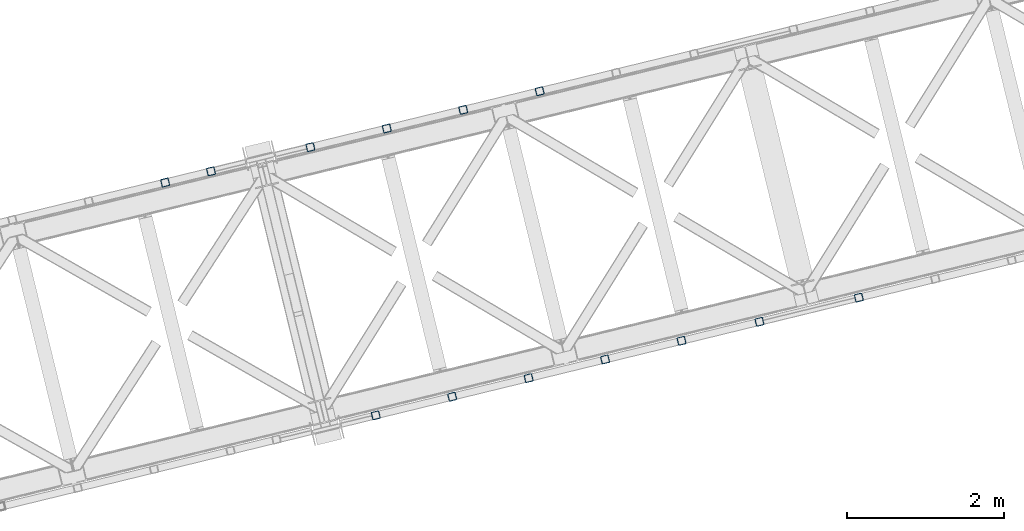
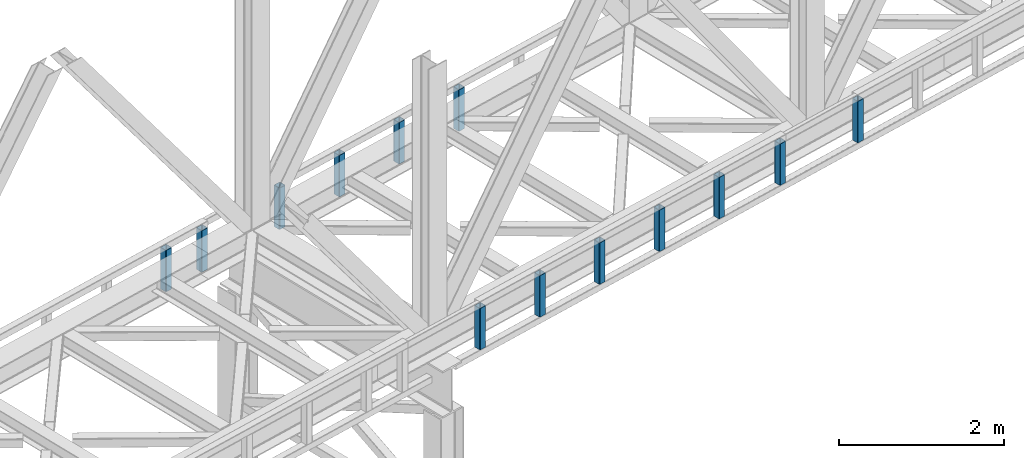
# One storey, part 9 of 93: 13 columns.
"""IFC4 building model written with IfcOpenShell, lengths in millimetres."""

from ifc_helpers import new_model, entity, si_unit, converted_unit, derived_unit, direction, frame, origin, place, context, subcontext, project, spatial, indexed_curve, outline, extrude, type_object, element, save


model = new_model("IFC4")

# Units and contexts
model_context = context("Model", 3, precision=0.01, world=origin(), true_north=direction((6.12303176911189e-17, 1.0)))
plan_context = context("Plan", 3, precision=0.01, world=origin(), true_north=direction((6.12303176911189e-17, 1.0)))
body_context = subcontext(model_context, "Body", "Model", "MODEL_VIEW")
ifc_project = project(units=[si_unit("LENGTHUNIT", "METRE", prefix="MILLI"), si_unit("AREAUNIT", "SQUARE_METRE"), si_unit("VOLUMEUNIT", "CUBIC_METRE"), converted_unit("PLANEANGLEUNIT", "DEGREE", entity("IfcRatioMeasure", 0.0174532925199433), si_unit("PLANEANGLEUNIT", "RADIAN"), dimensions=[0, 0, 0, 0, 0, 0, 0]), si_unit("MASSUNIT", "GRAM", prefix="KILO"), derived_unit("MASSDENSITYUNIT", [(si_unit("MASSUNIT", "GRAM", prefix="KILO"), 1), (si_unit("LENGTHUNIT", "METRE"), -3)]), derived_unit("MOMENTOFINERTIAUNIT", [(si_unit("LENGTHUNIT", "METRE"), 4)]), si_unit("TIMEUNIT", "SECOND"), si_unit("FREQUENCYUNIT", "HERTZ"), si_unit("THERMODYNAMICTEMPERATUREUNIT", "DEGREE_CELSIUS"), derived_unit("THERMALTRANSMITTANCEUNIT", [(si_unit("MASSUNIT", "GRAM", prefix="KILO"), 1), (si_unit("THERMODYNAMICTEMPERATUREUNIT", "KELVIN"), -1), (si_unit("TIMEUNIT", "SECOND"), -3)]), derived_unit("VOLUMETRICFLOWRATEUNIT", [(si_unit("LENGTHUNIT", "METRE"), 3), (si_unit("TIMEUNIT", "SECOND"), -1)]), derived_unit("MASSFLOWRATEUNIT", [(si_unit("MASSUNIT", "GRAM", prefix="KILO"), 1), (si_unit("TIMEUNIT", "SECOND"), -1)]), derived_unit("ROTATIONALFREQUENCYUNIT", [(si_unit("TIMEUNIT", "SECOND"), -1)]), si_unit("ELECTRICCURRENTUNIT", "AMPERE"), si_unit("ELECTRICVOLTAGEUNIT", "VOLT"), si_unit("POWERUNIT", "WATT"), si_unit("FORCEUNIT", "NEWTON", prefix="KILO"), si_unit("ILLUMINANCEUNIT", "LUX"), si_unit("LUMINOUSFLUXUNIT", "LUMEN"), si_unit("LUMINOUSINTENSITYUNIT", "CANDELA"), derived_unit("USERDEFINED", [(si_unit("MASSUNIT", "GRAM", prefix="KILO"), -1), (si_unit("LENGTHUNIT", "METRE"), -2), (si_unit("TIMEUNIT", "SECOND"), 3), (si_unit("LUMINOUSFLUXUNIT", "LUMEN"), 1)]), derived_unit("LINEARVELOCITYUNIT", [(si_unit("LENGTHUNIT", "METRE"), 1), (si_unit("TIMEUNIT", "SECOND"), -1)]), si_unit("PRESSUREUNIT", "PASCAL"), derived_unit("USERDEFINED", [(si_unit("LENGTHUNIT", "METRE"), -2), (si_unit("MASSUNIT", "GRAM", prefix="KILO"), 1), (si_unit("TIMEUNIT", "SECOND"), -2)]), derived_unit("LINEARFORCEUNIT", [(si_unit("MASSUNIT", "GRAM", prefix="KILO"), 1), (si_unit("LENGTHUNIT", "METRE"), 1), (si_unit("TIMEUNIT", "SECOND"), -2), (si_unit("LENGTHUNIT", "METRE"), -1)]), derived_unit("PLANARFORCEUNIT", [(si_unit("MASSUNIT", "GRAM", prefix="KILO"), 1), (si_unit("LENGTHUNIT", "METRE"), 1), (si_unit("TIMEUNIT", "SECOND"), -2), (si_unit("LENGTHUNIT", "METRE"), -2)])], contexts=[model_context, plan_context])

# Site, building, storey
site_placement = place(None, origin())
site = spatial("IfcSite", under=ifc_project, at=site_placement, CompositionType="ELEMENT")
building_placement = place(site_placement, origin())
building = spatial("IfcBuilding", under=site, at=building_placement, CompositionType="ELEMENT")
storey_placement = place(building_placement, frame((0.0, 0.0, 15900.0)))
storey = spatial("IfcBuildingStorey", under=building, at=storey_placement, CompositionType="ELEMENT", Elevation=15900.0)

# Columns
column_type_1 = type_object("IfcColumnType", PredefinedType="COLUMN")
column_1_placement = place(storey_placement, origin())
element("IfcColumn", 1, at=column_1_placement, inside=storey, type_object=column_type_1, ObjectType="Steel Column", PredefinedType="COLUMN", context=body_context, shape_type="SweptSolid", body=[
    extrude(outline(indexed_curve([(29.4768951153068, -56.8428769008217), (33.3787015556268, -56.8428769008217), (36.9835006656593, -55.3497202198167), (39.7424944584929, -52.5907264269884), (41.2356511394991, -48.9859273169536), (56.8428769008239, 29.4768951152962), (56.8428769008277, 33.3787015556192), (55.3497202198177, 36.9835006656564), (52.5907264269925, 39.7424944584862), (48.9859273169625, 41.2356511394926), (-29.4768951152941, 56.8428769008181), (-33.378701555618, 56.84287690082), (-36.9835006656514, 55.349720219813), (-39.7424944584841, 52.5907264269868), (-41.2356511394904, 48.9859273169519), (-56.8428769008112, -29.4768951152997), (-56.8428769008189, -33.3787015556209), (-55.3497202198089, -36.9835006656581), (-52.5907264269837, -39.7424944584879), (-48.9859273169498, -41.2356511394961), (29.4768951153068, -56.8428769008217)], self_intersect=False), holes=[indexed_curve([(-43.1065493048469, -37.3071763475629), (-46.7113484148769, -35.8140196665565), (-49.470342207706, -33.0550258737249), (-50.9634988887121, -29.4502267636895), (-50.9634988887131, -25.5484203233666), (-37.3071763475533, 43.106549304852), (-35.8140196665471, 46.7113484148868), (-33.0550258737135, 49.470342207715), (-29.4502267636761, 50.9634988887202), (-25.5484203233571, 50.9634988887182), (43.1065493048605, 37.3071763475613), (46.7113484148953, 35.8140196665551), (49.4703422077302, 33.0550258737255), (50.9634988887296, 29.4502267636861), (50.9634988887306, 25.5484203233633), (37.3071763475739, -43.1065493048592), (35.8140196665637, -46.7113484148922), (33.0550258737331, -49.4703422077242), (29.4502267636888, -50.9634988887237), (25.5484203233707, -50.9634988887198), (-43.1065493048469, -37.3071763475629)], self_intersect=False)]), frame((-26664.2270584381, 14498.5166149248, 3168.0), z_axis=(0.0, 0.0, 1.0), x_axis=(0.906681479027134, 0.421815949898968, 0.0)), (0.0, 0.0, 1.0), 612.000000000008),
])
column_type_2 = type_object("IfcColumnType", PredefinedType="COLUMN")
column_2_placement = place(storey_placement, origin())
element("IfcColumn", 2, at=column_2_placement, inside=storey, type_object=column_type_2, ObjectType="Steel Column", PredefinedType="COLUMN", context=body_context, shape_type="SweptSolid", body=[
    extrude(outline(indexed_curve([(29.4768951153139, -56.8428769008055), (33.3787015556426, -56.8428769008055), (36.9835006656793, -55.3497202197988), (39.7424944585069, -52.5907264269696), (41.2356511395155, -48.9859273169359), (56.8428769008033, 29.4768951153245), (56.8428769008045, 33.3787015556455), (55.3497202197968, 36.9835006656802), (52.5907264269665, 39.7424944585106), (48.9859273169271, 41.2356511395171), (-29.4768951153315, 56.8428769008089), (-33.3787015556514, 56.8428769008072), (-36.9835006656881, 55.3497202198005), (-39.7424944585108, 52.5907264269714), (-41.2356511395243, 48.9859273169376), (-56.842876900812, -29.4768951153228), (-56.8428769008093, -33.3787015556456), (-55.3497202198065, -36.9835006656805), (-52.5907264269753, -39.742494458509), (-48.9859273169447, -41.2356511395138), (29.4768951153139, -56.8428769008055)], self_intersect=False), holes=[indexed_curve([(-43.1065493048483, -37.3071763475781), (-46.711348414878, -35.8140196665713), (-49.4703422077083, -33.0550258737409), (-50.9634988887129, -29.45022676371), (-50.9634988887147, -25.5484203233852), (-37.3071763475856, 43.1065493048374), (-35.8140196665791, 46.7113484148768), (-33.0550258737515, 49.4703422077061), (-29.4502267637158, 50.9634988887108), (-25.5484203233958, 50.9634988887125), (43.1065493048316, 37.3071763475835), (46.7113484148662, 35.8140196665768), (49.4703422076956, 33.0550258737444), (50.963498888709, 29.4502267637118), (50.9634988887069, 25.5484203233888), (37.3071763475768, -43.1065493048357), (35.8140196665743, -46.7113484148769), (33.0550258737379, -49.4703422077045), (29.4502267636982, -50.9634988887074), (25.5484203233792, -50.9634988887072), (-43.1065493048483, -37.3071763475781)], self_intersect=False)]), frame((-27635.7791165796, 14261.6905219345, 3168.0), z_axis=(0.0, 0.0, 1.0), x_axis=(0.906681479027317, 0.421815949898576, 0.0)), (0.0, 0.0, 1.0), 612.000000000008),
])
column_type_3 = type_object("IfcColumnType", PredefinedType="COLUMN")
column_3_placement = place(storey_placement, origin())
element("IfcColumn", 3, at=column_3_placement, inside=storey, type_object=column_type_3, ObjectType="Steel Column", PredefinedType="COLUMN", context=body_context, shape_type="SweptSolid", body=[
    extrude(outline(indexed_curve([(29.4768951152902, -56.8428769008163), (33.3787015556102, -56.8428769008163), (36.9835006656514, -55.349720219813), (39.7424944584802, -52.5907264269849), (41.2356511394952, -48.9859273169518), (56.8428769008161, 29.4768951152999), (56.842876900815, 33.3787015556227), (55.3497202198089, 36.9835006656581), (52.5907264269798, 39.7424944584897), (48.9859273169459, 41.2356511394979), (-29.4768951153068, 56.8428769008217), (-33.3787015556268, 56.8428769008217), (-36.9835006656593, 55.3497202198166), (-39.742494458488, 52.5907264269886), (-41.235651139503, 48.9859273169554), (-56.8428769008239, -29.4768951152962), (-56.8428769008229, -33.3787015556191), (-55.3497202198177, -36.9835006656564), (-52.5907264269964, -39.7424944584844), (-48.9859273169625, -41.2356511394926), (29.4768951152902, -56.8428769008163)], self_intersect=False), holes=[indexed_curve([(-43.1065493048635, -37.3071763475575), (-46.7113484148896, -35.814019666553), (-49.4703422077169, -33.0550258737174), (-50.9634988887248, -29.450226763686), (-50.963498888721, -25.548420323363), (-37.307176347566, 43.1065493048555), (-35.814019666554, 46.7113484148924), (-33.055025873731, 49.4703422077184), (-29.4502267636928, 50.9634988887255), (-25.5484203233728, 50.9634988887255), (43.1065493048487, 37.3071763475668), (46.7113484148835, 35.8140196665606), (49.4703422077166, 33.0550258737271), (50.9634988887169, 29.4502267636896), (50.9634988887228, 25.5484203233669), (37.3071763475621, -43.1065493048537), (35.8140196665528, -46.7113484148847), (33.0550258737201, -49.470342207711), (29.450226763677, -50.9634988887182), (25.548420323358, -50.9634988887163), (-43.1065493048635, -37.3071763475575)], self_intersect=False)]), frame((-28607.331174721, 14024.8644289442, 3168.0), z_axis=(0.0, 0.0, 1.0), x_axis=(0.906681479027134, 0.421815949898968, 0.0)), (0.0, 0.0, 1.0), 612.000000000008),
])
column_type_4 = type_object("IfcColumnType", PredefinedType="COLUMN")
column_4_placement = place(storey_placement, origin())
element("IfcColumn", 4, at=column_4_placement, inside=storey, type_object=column_type_4, ObjectType="Steel Column", PredefinedType="COLUMN", context=body_context, shape_type="SweptSolid", body=[
    extrude(outline(indexed_curve([(29.476895115295, -56.8428769008162), (33.378701555615, -56.8428769008162), (36.9835006656514, -55.349720219813), (39.7424944584899, -52.5907264269846), (41.2356511394922, -48.985927316948), (56.842876900817, 29.4768951153019), (56.8428769008247, 33.378701555623), (55.3497202198098, 36.9835006656601), (52.5907264269807, 39.7424944584917), (48.9859273169507, 41.2356511394981), (-29.4768951152972, 56.8428769008219), (-33.378701555621, 56.8428769008238), (-36.9835006656544, 55.3497202198168), (-39.7424944584832, 52.5907264269887), (-41.2356511394934, 48.9859273169557), (-56.8428769008142, -29.476895115296), (-56.842876900818, -33.3787015556189), (-55.349720219812, -36.9835006656543), (-52.5907264269868, -39.7424944584841), (-48.9859273169529, -41.2356511394923), (29.476895115295, -56.8428769008162)], self_intersect=False), holes=[indexed_curve([(-43.1065493048596, -37.3071763475593), (-46.7113484148877, -35.814019666549), (-49.4703422077187, -33.0550258737213), (-50.9634988887199, -29.4502267636858), (-50.963498888721, -25.548420323363), (-37.3071763475572, 43.1065493048538), (-35.8140196665549, 46.7113484148905), (-33.0550258737253, 49.4703422077205), (-29.4502267636888, 50.9634988887237), (-25.5484203233689, 50.9634988887237), (43.1065493048575, 37.3071763475651), (46.7113484148865, 35.8140196665568), (49.4703422077175, 33.0550258737291), (50.9634988887178, 29.4502267636916), (50.9634988887237, 25.5484203233689), (37.307176347566, -43.1065493048555), (35.8140196665528, -46.7113484148847), (33.0550258737204, -49.4703422077206), (29.4502267636858, -50.9634988887199), (25.5484203233668, -50.9634988887179), (-43.1065493048596, -37.3071763475593)], self_intersect=False)]), frame((-29578.8832328625, 13788.0383359538, 3168.0), z_axis=(0.0, 0.0, 1.0), x_axis=(0.906681479027134, 0.421815949898968, 0.0)), (0.0, 0.0, 1.0), 612.000000000008),
])
column_type_5 = type_object("IfcColumnType", PredefinedType="COLUMN")
column_5_placement = place(storey_placement, origin())
element("IfcColumn", 5, at=column_5_placement, inside=storey, type_object=column_type_5, ObjectType="Steel Column", PredefinedType="COLUMN", context=body_context, shape_type="SweptSolid", body=[
    extrude(outline(indexed_curve([(29.476895115299, -56.842876900818), (33.3787015556189, -56.842876900818), (36.9835006656514, -55.349720219813), (39.7424944584899, -52.5907264269847), (41.2356511394952, -48.9859273169518), (56.842876900817, 29.4768951153019), (56.8428769008247, 33.378701555623), (55.3497202198098, 36.9835006656601), (52.5907264269886, 39.742494458488), (48.9859273169547, 41.2356511394962), (-29.476895115302, 56.8428769008218), (-33.378701555621, 56.8428769008238), (-36.9835006656544, 55.3497202198168), (-39.7424944584832, 52.5907264269887), (-41.2356511394982, 48.9859273169556), (-56.8428769008191, -29.4768951152961), (-56.842876900818, -33.3787015556189), (-55.3497202198129, -36.9835006656563), (-52.5907264269877, -39.7424944584861), (-48.9859273169577, -41.2356511394924), (29.476895115299, -56.842876900818)], self_intersect=False), holes=[indexed_curve([(-43.1065493048557, -37.3071763475612), (-46.7113484148856, -35.8140196665548), (-49.4703422077196, -33.0550258737233), (-50.9634988887208, -29.4502267636878), (-50.9634988887219, -25.548420323365), (-37.3071763475651, 43.1065493048575), (-35.814019666554, 46.7113484148924), (-33.0550258737213, 49.4703422077187), (-29.450226763684, 50.9634988887238), (-25.548420323365, 50.9634988887219), (43.1065493048526, 37.307176347565), (46.7113484148826, 35.8140196665586), (49.4703422077175, 33.0550258737291), (50.9634988887257, 29.4502267636879), (50.9634988887228, 25.5484203233669), (37.3071763475699, -43.1065493048573), (35.814019666551, -46.7113484148886), (33.0550258737204, -49.4703422077206), (29.450226763681, -50.96349888872), (25.5484203233619, -50.9634988887181), (-43.1065493048557, -37.3071763475612)], self_intersect=False)]), frame((-30841.9009084464, 13480.1644150664, 3168.0), z_axis=(0.0, 0.0, 1.0), x_axis=(0.906681479027134, 0.421815949898968, 0.0)), (0.0, 0.0, 1.0), 612.000000000008),
])
column_type_6 = type_object("IfcColumnType", PredefinedType="COLUMN")
column_6_placement = place(storey_placement, origin())
element("IfcColumn", 6, at=column_6_placement, inside=storey, type_object=column_type_6, ObjectType="Steel Column", PredefinedType="COLUMN", context=body_context, shape_type="SweptSolid", body=[
    extrude(outline(indexed_curve([(29.4768951152941, -56.8428769008181), (33.3787015556141, -56.8428769008181), (36.9835006656466, -55.3497202198131), (39.742494458485, -52.5907264269848), (41.2356511394904, -48.9859273169519), (56.8428769008121, 29.4768951153017), (56.8428769008198, 33.3787015556228), (55.349720219805, 36.9835006656599), (52.5907264269837, 39.7424944584879), (48.9859273169498, 41.2356511394961), (-29.4768951153068, 56.8428769008217), (-33.3787015556259, 56.8428769008236), (-36.9835006656593, 55.3497202198167), (-39.742494458488, 52.5907264269886), (-41.235651139503, 48.9859273169554), (-56.8428769008239, -29.4768951152962), (-56.8428769008229, -33.3787015556191), (-55.3497202198177, -36.9835006656564), (-52.5907264269925, -39.7424944584862), (-48.9859273169625, -41.2356511394926), (29.4768951152941, -56.8428769008181)], self_intersect=False), holes=[indexed_curve([(-43.1065493048605, -37.3071763475613), (-46.7113484148886, -35.814019666551), (-49.4703422077196, -33.0550258737233), (-50.9634988887208, -29.4502267636878), (-50.9634988887219, -25.548420323365), (-37.307176347566, 43.1065493048555), (-35.814019666554, 46.7113484148924), (-33.0550258737262, 49.4703422077185), (-29.4502267636888, 50.9634988887237), (-25.5484203233698, 50.9634988887217), (43.1065493048478, 37.3071763475648), (46.7113484148826, 35.8140196665586), (49.4703422077166, 33.0550258737271), (50.9634988887208, 29.4502267636878), (50.9634988887228, 25.5484203233669), (37.3071763475651, -43.1065493048575), (35.814019666551, -46.7113484148886), (33.0550258737195, -49.4703422077226), (29.4502267636761, -50.9634988887202), (25.5484203233571, -50.9634988887182), (-43.1065493048605, -37.3071763475613)], self_intersect=False)]), frame((-31424.8321433313, 13338.0687592722, 3168.0), z_axis=(0.0, 0.0, 1.0), x_axis=(0.906681479027134, 0.421815949898968, 0.0)), (0.0, 0.0, 1.0), 612.000000000008),
])
column_type_7 = type_object("IfcColumnType", PredefinedType="COLUMN")
column_7_placement = place(storey_placement, origin())
element("IfcColumn", 7, at=column_7_placement, inside=storey, type_object=column_type_7, ObjectType="Steel Column", PredefinedType="COLUMN", context=body_context, shape_type="SweptSolid", body=[
    extrude(outline(indexed_curve([(29.476895115299, -56.842876900818), (33.3787015556189, -56.842876900818), (36.9835006656554, -55.3497202198148), (39.742494458489, -52.5907264269866), (41.2356511394952, -48.9859273169518), (56.8428769008161, 29.4768951152999), (56.8428769008238, 33.378701555621), (55.3497202198138, 36.9835006656582), (52.5907264269847, 39.7424944584899), (48.9859273169547, 41.2356511394962), (-29.4768951152981, 56.84287690082), (-33.3787015556219, 56.8428769008218), (-36.9835006656544, 55.3497202198168), (-39.742494458488, 52.5907264269886), (-41.2356511394982, 48.9859273169556), (-56.84287690082, -29.4768951152981), (-56.8428769008229, -33.3787015556191), (-55.3497202198129, -36.9835006656563), (-52.5907264269916, -39.7424944584843), (-48.9859273169538, -41.2356511394943), (29.476895115299, -56.842876900818)], self_intersect=False), holes=[indexed_curve([(-43.1065493048557, -37.3071763475612), (-46.7113484148886, -35.814019666551), (-49.4703422077138, -33.0550258737212), (-50.9634988887248, -29.450226763686), (-50.9634988887258, -25.5484203233631), (-37.307176347569, 43.1065493048593), (-35.8140196665589, 46.7113484148923), (-33.0550258737213, 49.4703422077187), (-29.4502267636879, 50.9634988887257), (-25.548420323365, 50.9634988887219), (43.1065493048536, 37.3071763475669), (46.7113484148875, 35.8140196665587), (49.4703422077166, 33.0550258737271), (50.9634988887169, 29.4502267636896), (50.9634988887189, 25.5484203233687), (37.3071763475581, -43.1065493048519), (35.8140196665528, -46.7113484148847), (33.0550258737201, -49.470342207711), (29.4502267636858, -50.9634988887199), (25.5484203233668, -50.9634988887179), (-43.1065493048557, -37.3071763475612)], self_intersect=False)]), frame((-22607.6514651053, 11875.6030716343, 3168.0), z_axis=(0.0, 0.0, 1.0), x_axis=(-0.906681479027134, -0.421815949898968, 0.0)), (0.0, 0.0, 1.0), 612.000000000008),
])
column_type_8 = type_object("IfcColumnType", PredefinedType="COLUMN")
column_8_placement = place(storey_placement, origin())
element("IfcColumn", 8, at=column_8_placement, inside=storey, type_object=column_type_8, ObjectType="Steel Column", PredefinedType="COLUMN", context=body_context, shape_type="SweptSolid", body=[
    extrude(outline(indexed_curve([(29.476895115302, -56.8428769008218), (33.3787015556219, -56.8428769008218), (36.9835006656593, -55.3497202198167), (39.7424944584929, -52.5907264269884), (41.2356511394982, -48.9859273169556), (56.84287690082, 29.4768951152981), (56.8428769008277, 33.3787015556192), (55.3497202198177, 36.9835006656564), (52.5907264269877, 39.7424944584861), (48.9859273169577, 41.2356511394924), (-29.4768951152941, 56.8428769008181), (-33.3787015556141, 56.8428769008181), (-36.9835006656514, 55.349720219813), (-39.742494458485, 52.5907264269848), (-41.2356511394904, 48.9859273169519), (-56.8428769008121, -29.4768951153017), (-56.8428769008198, -33.3787015556228), (-55.3497202198098, -36.9835006656601), (-52.5907264269837, -39.7424944584879), (-48.9859273169498, -41.2356511394961), (29.476895115302, -56.8428769008218)], self_intersect=False), holes=[indexed_curve([(-43.1065493048526, -37.307176347565), (-46.7113484148886, -35.814019666551), (-49.4703422077175, -33.0550258737291), (-50.9634988887217, -29.4502267636897), (-50.9634988887219, -25.548420323365), (-37.3071763475572, 43.1065493048538), (-35.8140196665549, 46.7113484148905), (-33.0550258737204, 49.4703422077206), (-29.4502267636849, 50.9634988887219), (-25.5484203233619, 50.9634988887181), (43.1065493048566, 37.3071763475631), (46.7113484148905, 35.8140196665549), (49.4703422077187, 33.0550258737213), (50.9634988887208, 29.4502267636878), (50.9634988887219, 25.548420323365), (37.3071763475621, -43.1065493048537), (35.8140196665558, -46.7113484148885), (33.0550258737223, -49.4703422077167), (29.4502267636888, -50.9634988887237), (25.5484203233698, -50.9634988887217), (-43.1065493048526, -37.307176347565)], self_intersect=False)]), frame((-23870.6691406892, 11567.7291507469, 3168.0), z_axis=(0.0, 0.0, 1.0), x_axis=(-0.906681479027134, -0.421815949898968, 0.0)), (0.0, 0.0, 1.0), 612.000000000008),
])
column_type_9 = type_object("IfcColumnType", PredefinedType="COLUMN")
column_9_placement = place(storey_placement, origin())
element("IfcColumn", 9, at=column_9_placement, inside=storey, type_object=column_type_9, ObjectType="Steel Column", PredefinedType="COLUMN", context=body_context, shape_type="SweptSolid", body=[
    extrude(outline(indexed_curve([(29.4768951153038, -56.8428769008179), (33.3787015556238, -56.8428769008179), (36.9835006656602, -55.3497202198147), (39.742494458485, -52.5907264269848), (41.2356511395, -48.9859273169517), (56.8428769008209, 29.4768951153), (56.8428769008198, 33.3787015556229), (55.3497202198186, 36.9835006656584), (52.5907264269895, 39.74249445849), (48.9859273169595, 41.2356511394964), (-29.4768951152932, 56.8428769008201), (-33.378701555621, 56.8428769008238), (-36.9835006656584, 55.3497202198186), (-39.742494458488, 52.5907264269886), (-41.2356511394982, 48.9859273169556), (-56.8428769008191, -29.4768951152961), (-56.8428769008229, -33.3787015556191), (-55.3497202198168, -36.9835006656544), (-52.5907264269877, -39.7424944584861), (-48.9859273169489, -41.2356511394941), (29.4768951153038, -56.8428769008179)], self_intersect=False), holes=[indexed_curve([(-43.1065493048508, -37.307176347561), (-46.7113484148847, -35.8140196665528), (-49.4703422077138, -33.0550258737212), (-50.9634988887248, -29.450226763686), (-50.963498888721, -25.548420323363), (-37.3071763475612, 43.1065493048557), (-35.8140196665561, 46.7113484148982), (-33.0550258737204, 49.4703422077206), (-29.4502267636831, 50.9634988887258), (-25.5484203233601, 50.963498888722), (43.1065493048575, 37.3071763475651), (46.7113484148935, 35.8140196665511), (49.4703422077205, 33.0550258737253), (50.9634988887226, 29.4502267636917), (50.9634988887237, 25.5484203233689), (37.307176347563, -43.1065493048517), (35.8140196665558, -46.7113484148885), (33.0550258737232, -49.4703422077148), (29.4502267636907, -50.9634988887198), (25.5484203233707, -50.9634988887198), (-43.1065493048508, -37.307176347561)], self_intersect=False)]), frame((-24861.6522399935, 11326.1665358968, 3168.0), z_axis=(0.0, 0.0, 1.0), x_axis=(-0.906681479027134, -0.421815949898968, 0.0)), (0.0, 0.0, 1.0), 612.000000000008),
])
column_type_10 = type_object("IfcColumnType", PredefinedType="COLUMN")
column_10_placement = place(storey_placement, origin())
element("IfcColumn", 10, at=column_10_placement, inside=storey, type_object=column_type_10, ObjectType="Steel Column", PredefinedType="COLUMN", context=body_context, shape_type="SweptSolid", body=[
    extrude(outline(indexed_curve([(29.476895115302, -56.8428769008218), (33.3787015556219, -56.8428769008218), (36.9835006656584, -55.3497202198186), (39.742494458492, -52.5907264269904), (41.2356511394982, -48.9859273169556), (56.8428769008191, 29.4768951152961), (56.8428769008268, 33.3787015556172), (55.3497202198168, 36.9835006656544), (52.5907264269877, 39.7424944584861), (48.9859273169577, 41.2356511394924), (-29.476895115299, 56.842876900818), (-33.3787015556189, 56.842876900818), (-36.9835006656514, 55.349720219813), (-39.742494458485, 52.5907264269848), (-41.2356511394952, 48.9859273169518), (-56.842876900817, -29.4768951153019), (-56.8428769008198, -33.3787015556229), (-55.3497202198098, -36.9835006656601), (-52.5907264269886, -39.742494458488), (-48.9859273169547, -41.2356511394962), (29.476895115302, -56.8428769008218)], self_intersect=False), holes=[indexed_curve([(-43.1065493048526, -37.307176347565), (-46.7113484148914, -35.8140196665569), (-49.4703422077223, -33.0550258737292), (-50.9634988887226, -29.4502267636917), (-50.9634988887228, -25.5484203233669), (-37.307176347566, 43.1065493048555), (-35.8140196665558, 46.7113484148885), (-33.0550258737253, 49.4703422077205), (-29.4502267636849, 50.9634988887219), (-25.5484203233628, 50.9634988887161), (43.1065493048517, 37.307176347563), (46.7113484148838, 35.8140196665509), (49.4703422077138, 33.0550258737212), (50.9634988887199, 29.4502267636858), (50.963498888721, 25.548420323363), (37.3071763475612, -43.1065493048557), (35.8140196665549, -46.7113484148905), (33.0550258737174, -49.4703422077169), (29.450226763684, -50.9634988887238), (25.548420323365, -50.9634988887219), (-43.1065493048526, -37.307176347565)], self_intersect=False)]), frame((-25833.204298135, 11089.3404429064, 3168.0), z_axis=(0.0, 0.0, 1.0), x_axis=(-0.906681479027134, -0.421815949898968, 0.0)), (0.0, 0.0, 1.0), 612.000000000008),
])
column_type_11 = type_object("IfcColumnType", PredefinedType="COLUMN")
column_11_placement = place(storey_placement, origin())
element("IfcColumn", 11, at=column_11_placement, inside=storey, type_object=column_type_11, ObjectType="Steel Column", PredefinedType="COLUMN", context=body_context, shape_type="SweptSolid", body=[
    extrude(outline(indexed_curve([(29.4768951153315, -56.842876900805), (33.3787015556506, -56.842876900805), (36.9835006656871, -55.349720219798), (39.7424944585106, -52.5907264269667), (41.2356511395238, -48.9859273169329), (56.8428769008051, 29.4768951153267), (56.8428769008021, 33.3787015556495), (55.3497202197991, 36.9835006656843), (52.5907264269686, 39.7424944585145), (48.9859273169378, 41.2356511395191), (-29.4768951153227, 56.8428769008033), (-33.3787015556515, 56.842876900803), (-36.9835006656871, 55.349720219798), (-39.7424944585154, 52.5907264269666), (-41.2356511395238, 48.9859273169329), (-56.8428769008051, -29.4768951153267), (-56.842876900807, -33.3787015556496), (-55.3497202197991, -36.9835006656843), (-52.5907264269725, -39.7424944585127), (-48.9859273169291, -41.2356511395208), (29.4768951153315, -56.842876900805)], self_intersect=False), holes=[indexed_curve([(-43.1065493048329, -37.3071763475847), (-46.7113484148676, -35.8140196665783), (-49.4703422076981, -33.0550258737481), (-50.9634988887108, -29.4502267637136), (-50.963498888709, -25.5484203233906), (-37.3071763475838, 43.1065493048349), (-35.8140196665805, 46.7113484148782), (-33.0550258737462, 49.470342207702), (-29.4502267637096, 50.963498888709), (-25.5484203233867, 50.9634988887072), (43.1065493048378, 37.3071763475848), (46.7113484148746, 35.8140196665727), (49.470342207702, 33.0550258737462), (50.9634988887069, 29.4502267637154), (50.963498888709, 25.5484203233906), (37.3071763475838, -43.1065493048349), (35.8140196665784, -46.7113484148724), (33.0550258737471, -49.4703422077001), (29.4502267637154, -50.9634988887069), (25.5484203233954, -50.9634988887089), (-43.1065493048329, -37.3071763475847)], self_intersect=False)]), frame((-26804.7563562765, 10852.5143499161, 3168.0), z_axis=(0.0, 0.0, 1.0), x_axis=(-0.906681479027346, -0.421815949898512, 0.0)), (0.0, 0.0, 1.0), 612.000000000008),
])
column_type_12 = type_object("IfcColumnType", PredefinedType="COLUMN")
column_12_placement = place(storey_placement, origin())
element("IfcColumn", 12, at=column_12_placement, inside=storey, type_object=column_type_12, ObjectType="Steel Column", PredefinedType="COLUMN", context=body_context, shape_type="SweptSolid", body=[
    extrude(outline(indexed_curve([(29.476895115299, -56.842876900818), (33.3787015556189, -56.842876900818), (36.9835006656514, -55.349720219813), (39.7424944584811, -52.590726426983), (41.2356511394952, -48.9859273169518), (56.842876900817, 29.4768951153019), (56.8428769008159, 33.3787015556247), (55.3497202198098, 36.9835006656601), (52.5907264269886, 39.742494458488), (48.9859273169547, 41.2356511394962), (-29.4768951152972, 56.8428769008219), (-33.3787015556171, 56.8428769008219), (-36.9835006656584, 55.3497202198186), (-39.742494458488, 52.5907264269886), (-41.2356511395021, 48.9859273169574), (-56.8428769008239, -29.4768951152962), (-56.8428769008229, -33.3787015556191), (-55.3497202198168, -36.9835006656544), (-52.5907264269868, -39.7424944584841), (-48.9859273169529, -41.2356511394923), (29.476895115299, -56.842876900818)], self_intersect=False), holes=[indexed_curve([(-43.1065493048557, -37.3071763475612), (-46.7113484148905, -35.8140196665549), (-49.4703422077235, -33.0550258737215), (-50.9634988887238, -29.450226763684), (-50.9634988887297, -25.5484203233613), (-37.3071763475699, 43.1065493048573), (-35.8140196665598, 46.7113484148903), (-33.0550258737271, 49.4703422077166), (-29.4502267636879, 50.9634988887257), (-25.548420323365, 50.9634988887219), (43.1065493048526, 37.307176347565), (46.7113484148847, 35.8140196665528), (49.4703422077099, 33.055025873723), (50.9634988887178, 29.4502267636916), (50.963498888714, 25.5484203233686), (37.3071763475581, -43.1065493048519), (35.8140196665471, -46.7113484148868), (33.0550258737201, -49.470342207711), (29.4502267636858, -50.9634988887199), (25.5484203233659, -50.9634988887199), (-43.1065493048557, -37.3071763475612)], self_intersect=False)]), frame((-27776.308414418, 10615.6882569257, 3168.0), z_axis=(0.0, 0.0, 1.0), x_axis=(-0.906681479027134, -0.421815949898968, 0.0)), (0.0, 0.0, 1.0), 612.000000000008),
])
column_type_13 = type_object("IfcColumnType", PredefinedType="COLUMN")
column_13_placement = place(storey_placement, origin())
element("IfcColumn", 13, at=column_13_placement, inside=storey, type_object=column_type_13, ObjectType="Steel Column", PredefinedType="COLUMN", context=body_context, shape_type="SweptSolid", body=[
    extrude(outline(indexed_curve([(29.476895115299, -56.842876900818), (33.3787015556189, -56.842876900818), (36.9835006656563, -55.3497202198129), (39.742494458485, -52.5907264269848), (41.2356511394952, -48.9859273169518), (56.842876900817, 29.4768951153019), (56.8428769008198, 33.3787015556228), (55.3497202198147, 36.9835006656602), (52.5907264269886, 39.742494458488), (48.9859273169547, 41.2356511394962), (-29.4768951152932, 56.8428769008201), (-33.3787015556132, 56.8428769008201), (-36.9835006656496, 55.3497202198169), (-39.742494458488, 52.5907264269886), (-41.2356511394934, 48.9859273169557), (-56.8428769008151, -29.4768951152979), (-56.8428769008229, -33.3787015556191), (-55.349720219808, -36.9835006656561), (-52.5907264269828, -39.7424944584859), (-48.9859273169489, -41.2356511394941), (29.476895115299, -56.842876900818)], self_intersect=False), holes=[indexed_curve([(-43.1065493048557, -37.3071763475612), (-46.7113484148886, -35.814019666551), (-49.4703422077166, -33.0550258737271), (-50.963498888716, -29.4502267636876), (-50.9634988887219, -25.548420323365), (-37.3071763475651, 43.1065493048575), (-35.814019666551, 46.7113484148886), (-33.0550258737195, 49.4703422077226), (-29.4502267636879, 50.9634988887257), (-25.548420323365, 50.9634988887219), (43.1065493048575, 37.3071763475651), (46.7113484148926, 35.8140196665492), (49.4703422077205, 33.0550258737253), (50.9634988887217, 29.4502267636897), (50.9634988887228, 25.5484203233669), (37.3071763475591, -43.1065493048499), (35.8140196665568, -46.7113484148865), (33.0550258737232, -49.4703422077148), (29.4502267636907, -50.9634988887198), (25.5484203233707, -50.9634988887198), (-43.1065493048557, -37.3071763475612)], self_intersect=False)]), frame((-28747.8604725594, 10378.8621639354, 3168.0), z_axis=(0.0, 0.0, 1.0), x_axis=(-0.906681479027134, -0.421815949898968, 0.0)), (0.0, 0.0, 1.0), 612.000000000008),
])

save(model, "model.ifc")
